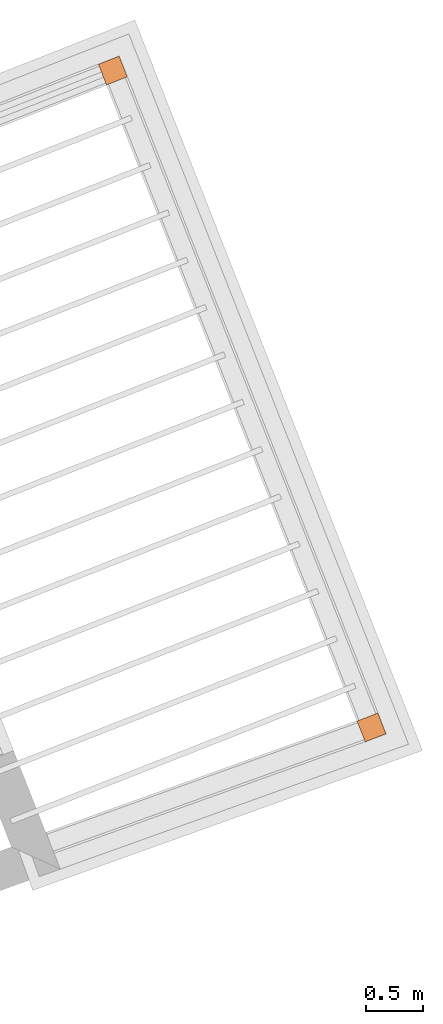
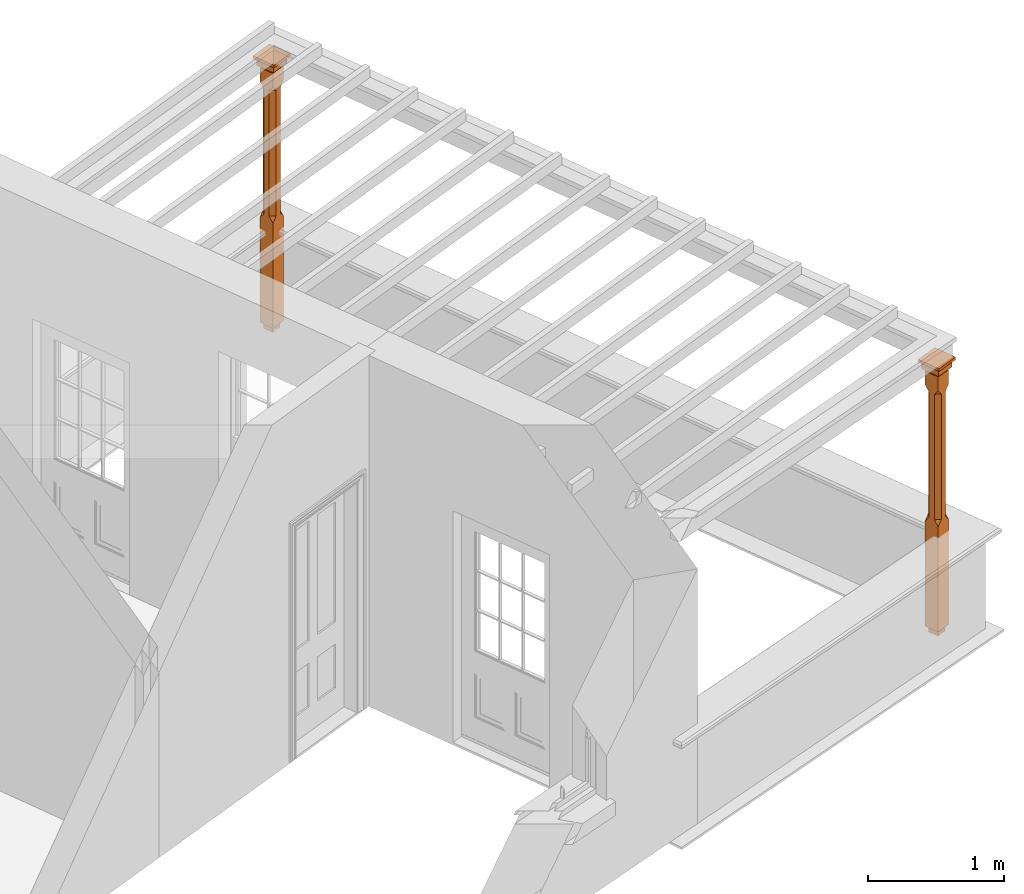
# One storey, part 8 of 8: 2 proxies.
"""IFC2X3 building model written with IfcOpenShell, lengths in metres."""

from ifc_helpers import new_model, si_unit, frame, origin, place, context, subcontext, project, spatial, faceted_brep, element, save


model = new_model("IFC2X3")

# Units and contexts
model_context = context("Model", 3, world=origin())
body_context = subcontext(model_context, "Body", "Model", "MODEL_VIEW")
ifc_project = project(units=[si_unit("PLANEANGLEUNIT", "RADIAN"), si_unit("MASSUNIT", "GRAM", prefix="KILO"), si_unit("FORCEUNIT", "NEWTON", prefix="KILO"), si_unit("LENGTHUNIT", "METRE")], contexts=[model_context])

# Site, building, storey
site_placement = place(None, origin())
site = spatial("IfcSite", under=ifc_project, at=site_placement, CompositionType="ELEMENT")
building_placement = place(None, origin())
building = spatial("IfcBuilding", under=site, at=building_placement, Name="Building plot-4", CompositionType="ELEMENT")
storey_placement = place(None, frame((0.0, 0.0, 9.45)))
storey = spatial("IfcBuildingStorey", under=building, at=storey_placement, Name="Floor 2", CompositionType="ELEMENT", Elevation=9.45)

# Proxies
proxy_1_placement = place(storey_placement, frame((57.3408758489428, 49.2344604185257, 0.0), z_axis=(0.0, 0.0, 1.0), x_axis=(-0.366428422179246, 0.930446243164659, 0.0)))
element("IfcBuildingElementProxy", 1, at=proxy_1_placement, inside=storey, Name="pergola post", CompositionType="ELEMENT", context=body_context, shape_type="Brep", held_by="IfcProductRepresentation", body=[
    faceted_brep([(0.0246, -0.0615, 2.17), (0.0615, -0.0246, 2.17), (0.0615, -0.0615, 2.216667), (0.0615, -0.0246, 1.044444), (0.0246, -0.0615, 1.044444), (0.0615, 0.0246, 2.17), (0.0615, 0.0615, 2.216667), (-0.0246, -0.0615, 2.17), (-0.0615, -0.0615, 2.216667), (-0.0246, -0.0615, 1.044444), (0.0615, -0.0615, 0.997778), (0.0615, 0.0246, 1.044444), (0.0246, 0.0615, 2.17), (0.0615, 0.0615, 2.341111), (0.0615, -0.0615, 2.341111), (-0.0615, -0.0615, 2.341111), (-0.0615, -0.0246, 2.17), (-0.0615, -0.0246, 1.044444), (-0.0615, -0.0615, 0.997778), (0.0615, 0.0615, 0.997778), (0.0246, 0.0615, 1.044444), (-0.0246, 0.0615, 2.17), (-0.0615, 0.0615, 2.216667), (0.04305, 0.04305, 2.341111), (0.04305, -0.04305, 2.341111), (-0.0615, 0.0615, 2.341111), (-0.04305, -0.04305, 2.341111), (-0.0615, 0.0246, 2.17), (-0.0615, 0.0246, 1.044444), (0.0615, -0.0615, 0.053333), (-0.0615, -0.0615, 0.053333), (0.0615, 0.0615, 0.053333), (-0.0246, 0.0615, 1.044444), (-0.04305, 0.04305, 2.341111), (0.04305, 0.04305, 2.364444), (0.04305, -0.04305, 2.364444), (-0.04305, -0.04305, 2.364444), (-0.0615, 0.0615, 0.997778), (-0.0615, 0.0615, 0.053333), (-0.04305, -0.04305, 0.053333), (0.04305, -0.04305, 0.053333), (0.04305, 0.04305, 0.053333), (-0.04305, 0.04305, 2.364444), (0.07995, 0.07995, 2.364444), (0.07995, -0.07995, 2.364444), (-0.07995, -0.07995, 2.364444), (-0.04305, 0.04305, 0.053333), (-0.04305, -0.04305, 0.0), (0.04305, -0.04305, 0.0), (0.04305, 0.04305, 0.0), (-0.07995, 0.07995, 2.364444), (0.07995, 0.07995, 2.426667), (0.07995, -0.07995, 2.426667), (-0.07995, -0.07995, 2.426667), (-0.04305, 0.04305, 0.0), (-0.07995, 0.07995, 2.426667), (0.0984, 0.0984, 2.426667), (0.0984, -0.0984, 2.426667), (-0.0984, -0.0984, 2.426667), (-0.0984, 0.0984, 2.426667), (0.0984, 0.0984, 2.45), (0.0984, -0.0984, 2.45), (-0.0984, -0.0984, 2.45), (-0.0984, 0.0984, 2.45)], [[[0, 1, 2]], [[3, 1, 0, 4]], [[1, 5, 6, 2]], [[7, 0, 2, 8]], [[4, 0, 7, 9]], [[3, 4, 10]], [[1, 3, 11, 5]], [[5, 12, 6]], [[13, 14, 2, 6]], [[15, 8, 2, 14]], [[8, 16, 7]], [[9, 7, 16, 17]], [[9, 18, 10, 4]], [[3, 10, 19, 11]], [[20, 12, 5, 11]], [[21, 22, 6, 12]], [[14, 13, 23, 24]], [[13, 6, 22, 25]], [[25, 22, 8, 15]], [[26, 15, 14, 24]], [[16, 8, 22, 27]], [[27, 28, 17, 16]], [[17, 18, 9]], [[29, 10, 18, 30]], [[31, 19, 10, 29]], [[20, 11, 19]], [[12, 20, 32, 21]], [[21, 27, 22]], [[33, 23, 13, 25]], [[23, 34, 35, 24]], [[26, 33, 25, 15]], [[36, 26, 24, 35]], [[28, 27, 21, 32]], [[17, 28, 37, 18]], [[38, 30, 18, 37]], [[29, 30, 39, 40]], [[31, 38, 37, 19]], [[40, 41, 31, 29]], [[32, 20, 19, 37]], [[33, 42, 34, 23]], [[43, 44, 35, 34]], [[42, 33, 26, 36]], [[36, 35, 44, 45]], [[28, 32, 37]], [[46, 39, 30, 38]], [[39, 47, 48, 40]], [[46, 38, 31, 41]], [[49, 41, 40, 48]], [[43, 34, 42, 50]], [[43, 51, 52, 44]], [[45, 50, 42, 36]], [[53, 45, 44, 52]], [[46, 54, 47, 39]], [[54, 46, 41, 49]], [[50, 55, 51, 43]], [[56, 57, 52, 51]], [[55, 50, 45, 53]], [[53, 52, 57, 58]], [[56, 51, 55, 59]], [[56, 60, 61, 57]], [[58, 59, 55, 53]], [[62, 58, 57, 61]], [[59, 63, 60, 56]], [[63, 62, 61, 60]], [[58, 62, 63, 59]], [[47, 54, 49, 48]]]),
])
proxy_2_placement = place(storey_placement, frame((55.0519128662587, 55.0466651468468, 0.0), z_axis=(0.0, 0.0, 1.0), x_axis=(-0.930446243164666, -0.366428422179229, 0.0)))
element("IfcBuildingElementProxy", 2, at=proxy_2_placement, inside=storey, Name="pergola post", CompositionType="ELEMENT", context=body_context, shape_type="Brep", held_by="IfcProductRepresentation", body=[
    faceted_brep([(0.0246, -0.0615, 2.17), (0.0615, -0.0246, 2.17), (0.0615, -0.0615, 2.216667), (0.0615, -0.0246, 1.044444), (0.0246, -0.0615, 1.044444), (0.0615, 0.0246, 2.17), (0.0615, 0.0615, 2.216667), (-0.0246, -0.0615, 2.17), (-0.0615, -0.0615, 2.216667), (-0.0246, -0.0615, 1.044444), (0.0615, -0.0615, 0.997778), (0.0615, 0.0246, 1.044444), (0.0246, 0.0615, 2.17), (0.0615, 0.0615, 2.341111), (0.0615, -0.0615, 2.341111), (-0.0615, -0.0615, 2.341111), (-0.0615, -0.0246, 2.17), (-0.0615, -0.0246, 1.044444), (-0.0615, -0.0615, 0.997778), (0.0615, 0.0615, 0.997778), (0.0246, 0.0615, 1.044444), (-0.0246, 0.0615, 2.17), (-0.0615, 0.0615, 2.216667), (0.04305, 0.04305, 2.341111), (0.04305, -0.04305, 2.341111), (-0.0615, 0.0615, 2.341111), (-0.04305, -0.04305, 2.341111), (-0.0615, 0.0246, 2.17), (-0.0615, 0.0246, 1.044444), (0.0615, -0.0615, 0.053333), (-0.0615, -0.0615, 0.053333), (0.0615, 0.0615, 0.053333), (-0.0246, 0.0615, 1.044444), (-0.04305, 0.04305, 2.341111), (0.04305, 0.04305, 2.364444), (0.04305, -0.04305, 2.364444), (-0.04305, -0.04305, 2.364444), (-0.0615, 0.0615, 0.997778), (-0.0615, 0.0615, 0.053333), (-0.04305, -0.04305, 0.053333), (0.04305, -0.04305, 0.053333), (0.04305, 0.04305, 0.053333), (-0.04305, 0.04305, 2.364444), (0.07995, 0.07995, 2.364444), (0.07995, -0.07995, 2.364444), (-0.07995, -0.07995, 2.364444), (-0.04305, 0.04305, 0.053333), (-0.04305, -0.04305, 0.0), (0.04305, -0.04305, 0.0), (0.04305, 0.04305, 0.0), (-0.07995, 0.07995, 2.364444), (0.07995, 0.07995, 2.426667), (0.07995, -0.07995, 2.426667), (-0.07995, -0.07995, 2.426667), (-0.04305, 0.04305, 0.0), (-0.07995, 0.07995, 2.426667), (0.0984, 0.0984, 2.426667), (0.0984, -0.0984, 2.426667), (-0.0984, -0.0984, 2.426667), (-0.0984, 0.0984, 2.426667), (0.0984, 0.0984, 2.45), (0.0984, -0.0984, 2.45), (-0.0984, -0.0984, 2.45), (-0.0984, 0.0984, 2.45)], [[[0, 1, 2]], [[3, 1, 0, 4]], [[1, 5, 6, 2]], [[7, 0, 2, 8]], [[4, 0, 7, 9]], [[3, 4, 10]], [[1, 3, 11, 5]], [[5, 12, 6]], [[13, 14, 2, 6]], [[15, 8, 2, 14]], [[8, 16, 7]], [[9, 7, 16, 17]], [[9, 18, 10, 4]], [[3, 10, 19, 11]], [[20, 12, 5, 11]], [[21, 22, 6, 12]], [[14, 13, 23, 24]], [[13, 6, 22, 25]], [[25, 22, 8, 15]], [[26, 15, 14, 24]], [[16, 8, 22, 27]], [[27, 28, 17, 16]], [[17, 18, 9]], [[29, 10, 18, 30]], [[31, 19, 10, 29]], [[20, 11, 19]], [[12, 20, 32, 21]], [[21, 27, 22]], [[33, 23, 13, 25]], [[23, 34, 35, 24]], [[26, 33, 25, 15]], [[36, 26, 24, 35]], [[28, 27, 21, 32]], [[17, 28, 37, 18]], [[38, 30, 18, 37]], [[29, 30, 39, 40]], [[31, 38, 37, 19]], [[40, 41, 31, 29]], [[32, 20, 19, 37]], [[33, 42, 34, 23]], [[43, 44, 35, 34]], [[42, 33, 26, 36]], [[36, 35, 44, 45]], [[28, 32, 37]], [[46, 39, 30, 38]], [[39, 47, 48, 40]], [[46, 38, 31, 41]], [[49, 41, 40, 48]], [[43, 34, 42, 50]], [[43, 51, 52, 44]], [[45, 50, 42, 36]], [[53, 45, 44, 52]], [[46, 54, 47, 39]], [[54, 46, 41, 49]], [[50, 55, 51, 43]], [[56, 57, 52, 51]], [[55, 50, 45, 53]], [[53, 52, 57, 58]], [[56, 51, 55, 59]], [[56, 60, 61, 57]], [[58, 59, 55, 53]], [[62, 58, 57, 61]], [[59, 63, 60, 56]], [[63, 62, 61, 60]], [[58, 62, 63, 59]], [[47, 54, 49, 48]]]),
])

save(model, "model.ifc")
